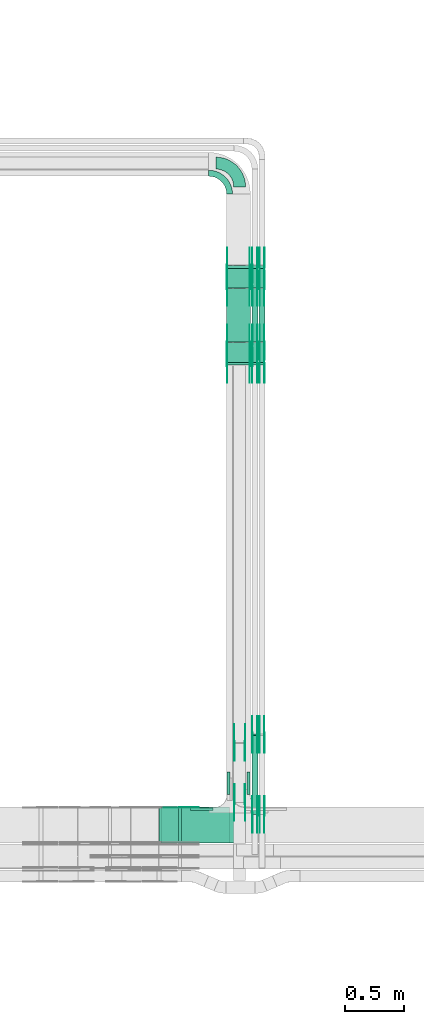
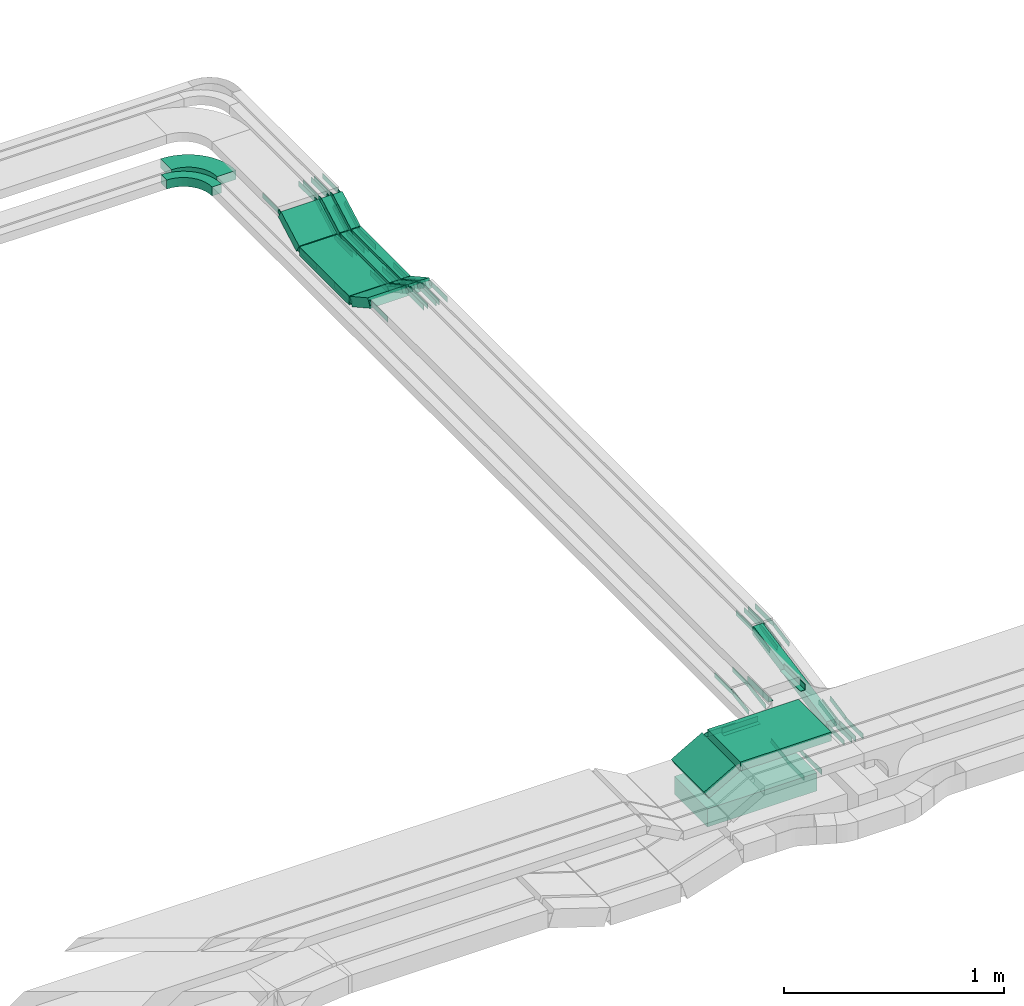
# One storey, part 14 of 28: 79 flow fittings, 13 flow segments.
"""IFC2X3 building model written with IfcOpenShell, lengths in millimetres."""

from ifc_helpers import new_model, entity, si_unit, converted_unit, derived_unit, direction, frame, frame_2d, origin, origin_2d_with_axis, place, context, subcontext, project, spatial, polyline, circle_curve, parameter, trimmed, segment, composite_curve, rectangle, outline, extrude, source, transform, mapped, material, type_object, type_shapes, element, save


model = new_model("IFC2X3")

# Units and contexts
model_context = context("Model", 3, precision=0.01, world=origin(), true_north=direction((6.12303176911189e-17, 1.0)))
body_context = subcontext(model_context, "Body", "Model", "MODEL_VIEW")
ifc_project = project(units=[si_unit("LENGTHUNIT", "METRE", prefix="MILLI"), si_unit("AREAUNIT", "SQUARE_METRE"), si_unit("VOLUMEUNIT", "CUBIC_METRE"), converted_unit("PLANEANGLEUNIT", "DEGREE", entity("IfcRatioMeasure", 0.0174532925199433), si_unit("PLANEANGLEUNIT", "RADIAN"), dimensions=[0, 0, 0, 0, 0, 0, 0]), si_unit("MASSUNIT", "GRAM", prefix="KILO"), derived_unit("MASSDENSITYUNIT", [(si_unit("MASSUNIT", "GRAM", prefix="KILO"), 1), (si_unit("LENGTHUNIT", "METRE"), -3)]), derived_unit("MOMENTOFINERTIAUNIT", [(si_unit("LENGTHUNIT", "METRE"), 4)]), si_unit("TIMEUNIT", "SECOND"), si_unit("FREQUENCYUNIT", "HERTZ"), si_unit("THERMODYNAMICTEMPERATUREUNIT", "DEGREE_CELSIUS"), derived_unit("THERMALTRANSMITTANCEUNIT", [(si_unit("MASSUNIT", "GRAM", prefix="KILO"), 1), (si_unit("THERMODYNAMICTEMPERATUREUNIT", "KELVIN"), -1), (si_unit("TIMEUNIT", "SECOND"), -3)]), derived_unit("VOLUMETRICFLOWRATEUNIT", [(si_unit("LENGTHUNIT", "METRE"), 3), (si_unit("TIMEUNIT", "SECOND"), -1)]), derived_unit("MASSFLOWRATEUNIT", [(si_unit("MASSUNIT", "GRAM", prefix="KILO"), 1), (si_unit("TIMEUNIT", "SECOND"), -1)]), derived_unit("ROTATIONALFREQUENCYUNIT", [(si_unit("TIMEUNIT", "SECOND"), -1)]), si_unit("ELECTRICCURRENTUNIT", "AMPERE"), si_unit("ELECTRICVOLTAGEUNIT", "VOLT"), si_unit("POWERUNIT", "WATT"), si_unit("FORCEUNIT", "NEWTON", prefix="KILO"), si_unit("ILLUMINANCEUNIT", "LUX"), si_unit("LUMINOUSFLUXUNIT", "LUMEN"), si_unit("LUMINOUSINTENSITYUNIT", "CANDELA"), derived_unit("USERDEFINED", [(si_unit("MASSUNIT", "GRAM", prefix="KILO"), -1), (si_unit("LENGTHUNIT", "METRE"), -2), (si_unit("TIMEUNIT", "SECOND"), 3), (si_unit("LUMINOUSFLUXUNIT", "LUMEN"), 1)]), derived_unit("LINEARVELOCITYUNIT", [(si_unit("LENGTHUNIT", "METRE"), 1), (si_unit("TIMEUNIT", "SECOND"), -1)]), si_unit("PRESSUREUNIT", "PASCAL"), derived_unit("USERDEFINED", [(si_unit("LENGTHUNIT", "METRE"), -2), (si_unit("MASSUNIT", "GRAM", prefix="KILO"), 1), (si_unit("TIMEUNIT", "SECOND"), -2)]), derived_unit("LINEARFORCEUNIT", [(si_unit("MASSUNIT", "GRAM", prefix="KILO"), 1), (si_unit("LENGTHUNIT", "METRE"), 1), (si_unit("TIMEUNIT", "SECOND"), -2), (si_unit("LENGTHUNIT", "METRE"), -1)]), derived_unit("PLANARFORCEUNIT", [(si_unit("MASSUNIT", "GRAM", prefix="KILO"), 1), (si_unit("LENGTHUNIT", "METRE"), 1), (si_unit("TIMEUNIT", "SECOND"), -2), (si_unit("LENGTHUNIT", "METRE"), -2)])], contexts=[model_context])

# Site, building, storey
site_placement = place(None, frame((0.0, -0.00077364408347762, 0.0)))
site = spatial("IfcSite", under=ifc_project, at=site_placement, CompositionType="ELEMENT")
building_placement = place(site_placement, origin())
building = spatial("IfcBuilding", under=site, at=building_placement, CompositionType="ELEMENT")
storey_placement = place(building_placement, origin())
storey = spatial("IfcBuildingStorey", under=building, at=storey_placement, CompositionType="ELEMENT", Elevation=0.0)

# Flow segments
cable_carrier_segment_type = type_object("IfcCableCarrierSegmentType", PredefinedType="CABLETRAYSEGMENT")
flow_segment_1_placement = place(storey_placement, frame((34944.2305815424, 8620.00006103523, 2600.0)))
element("IfcFlowSegment", 1, at=flow_segment_1_placement, inside=storey, type_object=cable_carrier_segment_type, context=body_context, shape_type="SweptSolid", body=[
    extrude(rectangle(XDim=574.87795341654, YDim=299.999999999999, at=frame_2d((-2.1600499167107e-12, -5.40012479177676e-13), x_axis=(1.0, 0.0))), frame((287.438976708272, 150.0, 0.0), z_axis=(0.0, 0.0, 1.0), x_axis=(-1.0, 0.0, 0.0)), (0.0, 0.0, 1.0), 100.0),
])
flow_segment_2_placement = place(storey_placement, frame((35117.8214366615, 8620.00006103513, 2850.0)))
element("IfcFlowSegment", 2, at=flow_segment_2_placement, inside=storey, type_object=cable_carrier_segment_type, context=body_context, shape_type="SweptSolid", body=[
    extrude(rectangle(XDim=476.287098297512, YDim=300.000000000001, at=origin_2d_with_axis()), frame((238.143549148756, 150.0, 0.0), z_axis=(0.0, 0.0, 1.0), x_axis=(-1.0, 0.0, 0.0)), (0.0, 0.0, 1.0), 50.0000000000005),
])
flow_segment_3_placement = place(storey_placement, frame((34927.1059649383, 8620.00006103513, 2756.67195783192)))
element("IfcFlowSegment", 3, at=flow_segment_3_placement, inside=storey, type_object=cable_carrier_segment_type, context=body_context, shape_type="SweptSolid", body=[
    extrude(rectangle(XDim=50.0000000000026, YDim=186.565135153123, at=frame_2d((0.0, 0.0), x_axis=(0.0, 1.0))), frame((93.4336609654781, 0.0, 67.8800710275627), z_axis=(0.0, 1.0, 0.0), x_axis=(-0.869016356406515, 0.0, -0.494783358954144)), (0.0, 0.0, 1.0), 299.999999999999),
])
flow_segment_4_placement = place(storey_placement, frame((35495.108534959, 12636.100454036, 2757.25534543462)))
element("IfcFlowSegment", 4, at=flow_segment_4_placement, inside=storey, type_object=cable_carrier_segment_type, context=body_context, shape_type="SweptSolid", body=[
    extrude(rectangle(XDim=49.9999999999987, YDim=189.266714071958, at=frame_2d((0.0, 0.0), x_axis=(0.0, 1.0))), frame((0.0, 94.8884395227133, 67.7446545653522), z_axis=(1.0, 0.0, 0.0), x_axis=(0.0, 0.874619707142013, -0.484809620241615)), (0.0, 0.0, 1.0), 199.999999999998),
])
flow_segment_5_placement = place(storey_placement, frame((35495.108534959, 12829.6911912687, 2750.0)))
element("IfcFlowSegment", 5, at=flow_segment_5_placement, inside=storey, type_object=cable_carrier_segment_type, context=body_context, shape_type="SweptSolid", body=[
    extrude(rectangle(XDim=450.404775530849, YDim=199.999999999998, at=origin_2d_with_axis()), frame((100.0, 225.202387765424, 0.0), z_axis=(0.0, 0.0, 1.0), x_axis=(0.0, 1.0, 0.0)), (0.0, 0.0, 1.0), 49.9999999999995),
])
flow_segment_6_placement = place(storey_placement, frame((35495.108534959, 13283.909824987, 2757.25534543462)))
element("IfcFlowSegment", 6, at=flow_segment_6_placement, inside=storey, type_object=cable_carrier_segment_type, context=body_context, shape_type="SweptSolid", body=[
    extrude(rectangle(XDim=49.9999999999988, YDim=189.266714071933, at=frame_2d((-1.07291953099775e-12, 2.87769807982841e-13), x_axis=(0.0, 1.0))), frame((0.0, 94.8884395226938, 67.7446545653619), z_axis=(1.0, 0.0, 0.0), x_axis=(0.0, -0.874619707141901, -0.484809620241818)), (0.0, 0.0, 1.0), 199.999999999998),
])
flow_segment_7_placement = place(storey_placement, frame((35707.4596505076, 12636.100454036, 2757.25534543462)))
element("IfcFlowSegment", 7, at=flow_segment_7_placement, inside=storey, type_object=cable_carrier_segment_type, context=body_context, shape_type="SweptSolid", body=[
    extrude(rectangle(XDim=49.9999999999985, YDim=49.9999999999973, at=frame_2d((0.0, -2.36255459640233e-13), x_axis=(0.0, 1.0))), frame((25.0, 12.1202405060419, 113.623816452189), z_axis=(0.0, 0.874619707141971, -0.484809620241692), x_axis=(-1.0, 0.0, 0.0)), (0.0, 0.0, 1.0), 189.266714071994),
])
flow_segment_8_placement = place(storey_placement, frame((35707.4596505076, 12829.6911912687, 2750.0)))
element("IfcFlowSegment", 8, at=flow_segment_8_placement, inside=storey, type_object=cable_carrier_segment_type, context=body_context, shape_type="SweptSolid", body=[
    extrude(rectangle(XDim=450.404775530849, YDim=49.9999999999973, at=origin_2d_with_axis()), frame((25.0, 225.202387765424, 0.0), z_axis=(0.0, 0.0, 1.0), x_axis=(0.0, 1.0, 0.0)), (0.0, 0.0, 1.0), 49.9999999999995),
])
flow_segment_9_placement = place(storey_placement, frame((35707.4596505076, 13283.909824987, 2757.25534543462)))
element("IfcFlowSegment", 9, at=flow_segment_9_placement, inside=storey, type_object=cable_carrier_segment_type, context=body_context, shape_type="SweptSolid", body=[
    extrude(rectangle(XDim=49.9999999999974, YDim=49.9999999999973, at=origin_2d_with_axis()), frame((25.0, 12.1202405060463, 21.8654926785462), z_axis=(0.0, 0.874619707141869, 0.484809620241875), x_axis=(0.0, -0.484809620241875, 0.874619707141869)), (0.0, 0.0, 1.0), 189.266714071863),
])
flow_segment_10_placement = place(storey_placement, frame((35767.4596505076, 12636.1004540359, 2757.25534543461)))
element("IfcFlowSegment", 10, at=flow_segment_10_placement, inside=storey, type_object=cable_carrier_segment_type, context=body_context, shape_type="SweptSolid", body=[
    extrude(rectangle(XDim=50.0000000000002, YDim=49.9999999999973, at=frame_2d((0.0, 0.0), x_axis=(0.0, 1.0))), frame((25.0, 12.1202405060354, 113.623816452199), z_axis=(0.0, 0.874619707142124, -0.484809620241415), x_axis=(-1.0, 0.0, 0.0)), (0.0, 0.0, 1.0), 189.266714072121),
])
flow_segment_11_placement = place(storey_placement, frame((35767.4596505076, 12829.6911912687, 2750.0)))
element("IfcFlowSegment", 11, at=flow_segment_11_placement, inside=storey, type_object=cable_carrier_segment_type, context=body_context, shape_type="SweptSolid", body=[
    extrude(rectangle(XDim=450.404775530849, YDim=49.9999999999973, at=origin_2d_with_axis()), frame((25.0, 225.202387765424, 0.0), z_axis=(0.0, 0.0, 1.0), x_axis=(0.0, 1.0, 0.0)), (0.0, 0.0, 1.0), 49.9999999999995),
])
flow_segment_12_placement = place(storey_placement, frame((35767.4596505076, 13283.909824987, 2757.25534543462)))
element("IfcFlowSegment", 12, at=flow_segment_12_placement, inside=storey, type_object=cable_carrier_segment_type, context=body_context, shape_type="SweptSolid", body=[
    extrude(rectangle(XDim=49.9999999999981, YDim=49.9999999999973, at=frame_2d((-9.98312543742941e-13, 0.0), x_axis=(1.0, 0.0))), frame((25.0, 12.1202405060419, 21.8654926785478), z_axis=(0.0, 0.874619707141945, 0.484809620241739), x_axis=(0.0, -0.484809620241739, 0.874619707141945)), (0.0, 0.0, 1.0), 189.266714072015),
])
flow_segment_13_placement = place(storey_placement, frame((35707.4596505076, 8859.24285834248, 2722.15463457333)))
element("IfcFlowSegment", 13, at=flow_segment_13_placement, inside=storey, type_object=cable_carrier_segment_type, context=body_context, shape_type="SweptSolid", body=[
    extrude(rectangle(XDim=50.0000000000005, YDim=49.9999999999973, at=frame_2d((0.0, -1.01252339845814e-13), x_axis=(0.0, 1.0))), frame((25.0, 4.70828965747625, 24.5526375060055), z_axis=(0.0, 0.982105500240211, 0.18833158629907), x_axis=(-1.0, 0.0, 0.0)), (0.0, 0.0, 1.0), 677.451182505788),
])

# Flow fittings
ifc_material_1 = material(Name="G")
cable_carrier_fitting_type_1 = type_object("IfcCableCarrierFittingType", PredefinedType="NOTDEFINED", material=ifc_material_1)
shared_shape_1 = source(origin(), body_context, "Body", "SweptSolid", [
    extrude(outline(composite_curve([segment(trimmed(circle_curve(frame_2d((-44.5901162790698, 0.0), x_axis=(1.0, 0.0)), 12.5), [parameter(90.0000000000007)], [parameter(270.0)], True, "PARAMETER"), True, "CONTINUOUS"), segment(polyline([(-44.5901162790697, -12.5), (-33.0901162790698, -12.5)]), True, "CONTINUOUS"), segment(polyline([(-33.0901162790698, -12.5), (-31.2296511627907, -14.5)]), True, "CONTINUOUS"), segment(polyline([(-31.2296511627907, -14.5), (108.90988372093, -14.5)]), True, "CONTINUOUS"), segment(polyline([(108.90988372093, -14.5), (108.90988372093, 14.5)]), True, "CONTINUOUS"), segment(polyline([(108.90988372093, 14.5), (-31.2296511627907, 14.5)]), True, "CONTINUOUS"), segment(polyline([(-31.2296511627907, 14.5), (-33.0901162790698, 12.5)]), True, "CONTINUOUS"), segment(polyline([(-33.0901162790698, 12.5), (-44.5901162790699, 12.5)]), True, "CONTINUOUS")], self_intersect=False)), frame((44.5901162790698, 0.0, 0.0), z_axis=(0.0, 0.0, -1.0), x_axis=(1.0, 0.0, 0.0)), (0.0, 0.0, -1.0), 2.0),
])
type_shapes(cable_carrier_fitting_type_1, [shared_shape_1])
for number, where, z_axis, x_axis in (
    (14, (35559.6485349488, 9462.24837085622, 2625.0), (-1.0, 0.0, 0.0), (0.0, 1.0, 0.0)),
    (15, (35559.6485349488, 8957.89179254252, 2545.11776562734), (-1.0, 0.0, 0.0), (0.0, -1.0, 0.0)),
    (16, (35109.1442874699, 8915.46006104529, 2875.0), (0.0, 1.0, 0.0), (1.0, 0.0, 0.0)),
    (17, (35499.6485349488, 12640.7865057941, 2875.0), (-1.0, 0.0, 0.0), (0.0, 0.874619707139365, -0.484809620246393)),
    (18, (35499.6485349488, 12821.1912813235, 2775.0), (-1.0, 0.0, 0.0), (0.0, -0.874619707139365, 0.484809620246393)),
    (19, (35690.5685349691, 13469.0006522743, 2875.0), (1.0, 0.0, 0.0), (0.0, -0.874619707139365, -0.484809620246393)),
    (20, (35690.5685349691, 13288.595876745, 2775.0), (1.0, 0.0, 0.0), (0.0, 0.874619707139365, 0.484809620246393)),
    (21, (35711.9996504974, 12821.1912813235, 2775.0), (-1.0, 0.0, 0.0), (0.0, -0.874619707139365, 0.484809620246393)),
    (22, (35752.9196505177, 13288.595876745, 2775.0), (1.0, 0.0, 0.0), (0.0, 0.874619707139365, 0.484809620246393)),
    (23, (35711.9996504974, 13469.0006522742, 2875.0), (-1.0, 0.0, 0.0), (0.0, 1.0, 0.0)),
    (24, (35771.9996504974, 12821.1912813235, 2775.0), (-1.0, 0.0, 0.0), (0.0, -0.874619707139365, 0.484809620246393)),
    (25, (35812.9196505177, 13288.595876745, 2775.0), (1.0, 0.0, 0.0), (0.0, 0.874619707139365, 0.484809620246393)),
    (26, (35771.9996504974, 13469.0006522744, 2875.0), (-1.0, 0.0, 0.0), (0.0, 1.0, 0.0)),
    (27, (35812.9196505177, 12640.7865057939, 2875.0), (1.0, 0.0, 0.0), (0.0, -1.0, 0.0)),
    (28, (35812.9196505177, 8860.26288830369, 2746.0), (1.0, 0.0, 0.0), (0.0, 0.982105500240216, 0.188331586299048)),
    (29, (35812.9196505177, 9532.96794017931, 2875.0), (1.0, 0.0, 0.0), (0.0, -0.982105500240216, -0.188331586299048)),
    (30, (35752.9196505177, 8860.26288830369, 2746.0), (1.0, 0.0, 0.0), (0.0, 0.982105500240216, 0.188331586299048)),
    (31, (35752.9196505177, 12640.7865057941, 2875.0), (1.0, 0.0, 0.0), (0.0, -1.0, 0.0)),
    (32, (35711.9996504974, 9532.96794017937, 2875.0), (-1.0, 0.0, 0.0), (0.0, 1.0, 0.0)),
):
    element("IfcFlowFitting", number, at=place(storey_placement, frame(where, z_axis=z_axis, x_axis=x_axis)), inside=storey, type_object=cable_carrier_fitting_type_1, material=ifc_material_1, context=body_context, shape_type="MappedRepresentation", body=[
        mapped(shared_shape_1, transform((0.0, 0.0, 0.0), scale=1.0)),
    ])
cable_carrier_fitting_type_2 = type_object("IfcCableCarrierFittingType", PredefinedType="NOTDEFINED", material=ifc_material_1)
shared_shape_2 = source(origin(), body_context, "Body", "SweptSolid", [
    extrude(outline(composite_curve([segment(trimmed(circle_curve(frame_2d((-44.5901162790697, 0.0), x_axis=(1.0, 0.0)), 12.5), [parameter(90.0000000000007)], [parameter(270.0)], True, "PARAMETER"), True, "CONTINUOUS"), segment(polyline([(-44.5901162790697, -12.5), (-33.0901162790697, -12.5)]), True, "CONTINUOUS"), segment(polyline([(-33.0901162790697, -12.5), (-31.2296511627907, -14.5)]), True, "CONTINUOUS"), segment(polyline([(-31.2296511627907, -14.5), (108.90988372093, -14.5)]), True, "CONTINUOUS"), segment(polyline([(108.90988372093, -14.5), (108.90988372093, 14.5)]), True, "CONTINUOUS"), segment(polyline([(108.90988372093, 14.5), (-31.2296511627907, 14.5)]), True, "CONTINUOUS"), segment(polyline([(-31.2296511627907, 14.5), (-33.0901162790698, 12.5)]), True, "CONTINUOUS"), segment(polyline([(-33.0901162790698, 12.5), (-44.5901162790699, 12.5)]), True, "CONTINUOUS")], self_intersect=False)), frame((44.5901162790697, 0.0, 0.0)), (0.0, 0.0, 1.0), 2.0),
])
type_shapes(cable_carrier_fitting_type_2, [shared_shape_2])
for number, where, z_axis, x_axis in (
    (33, (35650.5685349691, 9462.24837085621, 2625.0), (1.0, 0.0, 0.0), (0.0, 1.0, 0.0)),
    (34, (35650.5685349691, 8957.89179254252, 2545.11776562734), (1.0, 0.0, 0.0), (0.0, -1.0, 0.0)),
    (35, (35690.5685349691, 12640.7865057941, 2875.0), (1.0, 0.0, 0.0), (0.0, 0.874619707139365, -0.484809620246393)),
    (36, (35690.5685349691, 12821.1912813235, 2775.0), (1.0, 0.0, 0.0), (0.0, -0.874619707139365, 0.484809620246393)),
    (37, (35499.6485349488, 13469.0006522743, 2875.0), (-1.0, 0.0, 0.0), (0.0, -0.874619707139365, -0.484809620246393)),
    (38, (35499.6485349488, 13288.595876745, 2775.0), (-1.0, 0.0, 0.0), (0.0, 0.874619707139365, 0.484809620246393)),
    (39, (35752.9196505177, 12821.1912813235, 2775.0), (1.0, 0.0, 0.0), (0.0, -0.874619707139365, 0.484809620246393)),
    (40, (35711.9996504974, 13288.595876745, 2775.0), (-1.0, 0.0, 0.0), (0.0, 0.874619707139365, 0.484809620246393)),
    (41, (35752.9196505177, 13469.0006522742, 2875.0), (1.0, 0.0, 0.0), (0.0, 1.0, 0.0)),
    (42, (35812.9196505177, 12821.1912813235, 2775.0), (1.0, 0.0, 0.0), (0.0, -0.874619707139365, 0.484809620246393)),
    (43, (35771.9996504974, 13288.595876745, 2775.0), (-1.0, 0.0, 0.0), (0.0, 0.874619707139365, 0.484809620246393)),
    (44, (35812.9196505177, 13469.0006522744, 2875.0), (1.0, 0.0, 0.0), (0.0, 1.0, 0.0)),
    (45, (35771.9996504974, 12640.7865057939, 2875.0), (-1.0, 0.0, 0.0), (0.0, -1.0, 0.0)),
    (46, (35771.9996504974, 8860.26288830368, 2746.0), (-1.0, 0.0, 0.0), (0.0, 0.982105500240216, 0.188331586299048)),
    (47, (35771.9996504974, 9532.96794017931, 2875.0), (-1.0, 0.0, 0.0), (0.0, -0.982105500240216, -0.188331586299048)),
    (48, (35711.9996504974, 8860.26288830368, 2746.0), (-1.0, 0.0, 0.0), (0.0, 0.982105500240216, 0.188331586299048)),
    (49, (35711.9996504974, 12640.7865057941, 2875.0), (-1.0, 0.0, 0.0), (0.0, -1.0, 0.0)),
    (50, (35752.9196505177, 9532.96794017937, 2875.0), (1.0, 0.0, 0.0), (0.0, 1.0, 0.0)),
):
    element("IfcFlowFitting", number, at=place(storey_placement, frame(where, z_axis=z_axis, x_axis=x_axis)), inside=storey, type_object=cable_carrier_fitting_type_2, material=ifc_material_1, context=body_context, shape_type="MappedRepresentation", body=[
        mapped(shared_shape_2, transform((0.0, 0.0, 0.0), scale=1.0)),
    ])
cable_carrier_fitting_type_3 = type_object("IfcCableCarrierFittingType", PredefinedType="NOTDEFINED", material=ifc_material_1)
shared_shape_3 = source(origin(), body_context, "Body", "SweptSolid", [
    extrude(outline(composite_curve([segment(trimmed(circle_curve(frame_2d((-44.5901162790698, 0.0), x_axis=(1.0, 0.0)), 12.5), [parameter(90.0000000000007)], [parameter(270.0)], True, "PARAMETER"), True, "CONTINUOUS"), segment(polyline([(-44.5901162790697, -12.5), (-33.0901162790698, -12.5)]), True, "CONTINUOUS"), segment(polyline([(-33.0901162790698, -12.5), (-31.2296511627907, -14.5)]), True, "CONTINUOUS"), segment(polyline([(-31.2296511627907, -14.5), (108.90988372093, -14.5)]), True, "CONTINUOUS"), segment(polyline([(108.90988372093, -14.5), (108.90988372093, 14.5)]), True, "CONTINUOUS"), segment(polyline([(108.90988372093, 14.5), (-31.2296511627907, 14.5)]), True, "CONTINUOUS"), segment(polyline([(-31.2296511627907, 14.5), (-33.0901162790698, 12.5)]), True, "CONTINUOUS"), segment(polyline([(-33.0901162790698, 12.5), (-44.5901162790699, 12.5)]), True, "CONTINUOUS")], self_intersect=False)), frame((44.5901162790698, 0.0, 0.0), z_axis=(0.0, 0.0, -1.0), x_axis=(1.0, 0.0, 0.0)), (0.0, 0.0, -1.0), 2.0),
])
type_shapes(cable_carrier_fitting_type_3, [shared_shape_3])
for number, where, z_axis, x_axis in (
    (51, (35648.5685349691, 9462.24837085623, 2625.0), (1.0, 0.0, 0.0), (0.0, -0.987688340595135, -0.15643446504025)),
    (52, (35648.5685349691, 8957.8917925425, 2545.11776562734), (1.0, 0.0, 0.0), (0.0, 0.987688340597445, 0.15643446502566)),
    (53, (35688.5685349691, 12640.7865057941, 2875.0), (1.0, 0.0, 0.0), (0.0, -1.0, 0.0)),
    (54, (35688.5685349691, 12821.1912813235, 2775.0), (1.0, 0.0, 0.0), (0.0, 1.0, 0.0)),
    (55, (35501.6485349488, 13469.0006522743, 2875.0), (-1.0, 0.0, 0.0), (0.0, 1.0, 0.0)),
    (56, (35501.6485349488, 13288.595876745, 2775.0), (-1.0, 0.0, 0.0), (0.0, -1.0, 0.0)),
    (57, (35750.9196505177, 12821.1912813235, 2775.0), (1.0, 0.0, 0.0), (0.0, 1.0, 0.0)),
    (58, (35713.9996504974, 13288.595876745, 2775.0), (-1.0, 0.0, 0.0), (0.0, -1.0, 0.0)),
    (59, (35750.9196505177, 13469.0006522742, 2875.0), (1.0, 0.0, 0.0), (0.0, -0.874619707141878, -0.484809620241859)),
    (60, (35810.9196505177, 12821.1912813235, 2775.0), (1.0, 0.0, 0.0), (0.0, 1.0, 0.0)),
    (61, (35773.9996504974, 13288.595876745, 2775.0), (-1.0, 0.0, 0.0), (0.0, -1.0, 0.0)),
    (62, (35810.9196505177, 13469.0006522744, 2875.0), (1.0, 0.0, 0.0), (0.0, -0.874619707141963, -0.484809620241705)),
    (63, (35773.9996504974, 12640.7865057939, 2875.0), (-1.0, 0.0, 0.0), (0.0, 0.874619707142149, -0.484809620241371)),
    (64, (35773.9996504974, 8860.2628883037, 2746.0), (-1.0, 0.0, 0.0), (0.0, -1.0, 0.0)),
    (65, (35773.9996504974, 9532.96794017929, 2875.0), (-1.0, 0.0, 0.0), (0.0, 1.0, 0.0)),
    (66, (35713.9996504974, 8860.2628883037, 2746.0), (-1.0, 0.0, 0.0), (0.0, -1.0, 0.0)),
    (67, (35713.9996504974, 12640.7865057941, 2875.0), (-1.0, 0.0, 0.0), (0.0, 0.874619707141962, -0.484809620241708)),
    (68, (35750.9196505177, 9532.96794017939, 2875.0), (1.0, 0.0, 0.0), (0.0, -0.982105500240217, -0.188331586299042)),
):
    element("IfcFlowFitting", number, at=place(storey_placement, frame(where, z_axis=z_axis, x_axis=x_axis)), inside=storey, type_object=cable_carrier_fitting_type_3, material=ifc_material_1, context=body_context, shape_type="MappedRepresentation", body=[
        mapped(shared_shape_3, transform((0.0, 0.0, 0.0), scale=1.0)),
    ])
cable_carrier_fitting_type_4 = type_object("IfcCableCarrierFittingType", PredefinedType="NOTDEFINED", material=ifc_material_1)
shared_shape_4 = source(origin(), body_context, "Body", "SweptSolid", [
    extrude(outline(composite_curve([segment(trimmed(circle_curve(frame_2d((-44.5901162790697, 0.0), x_axis=(1.0, 0.0)), 12.5), [parameter(90.0000000000007)], [parameter(270.0)], True, "PARAMETER"), True, "CONTINUOUS"), segment(polyline([(-44.5901162790697, -12.5), (-33.0901162790697, -12.5)]), True, "CONTINUOUS"), segment(polyline([(-33.0901162790697, -12.5), (-31.2296511627907, -14.5)]), True, "CONTINUOUS"), segment(polyline([(-31.2296511627907, -14.5), (108.90988372093, -14.5)]), True, "CONTINUOUS"), segment(polyline([(108.90988372093, -14.5), (108.90988372093, 14.5)]), True, "CONTINUOUS"), segment(polyline([(108.90988372093, 14.5), (-31.2296511627907, 14.5)]), True, "CONTINUOUS"), segment(polyline([(-31.2296511627907, 14.5), (-33.0901162790698, 12.5)]), True, "CONTINUOUS"), segment(polyline([(-33.0901162790698, 12.5), (-44.5901162790699, 12.5)]), True, "CONTINUOUS")], self_intersect=False)), frame((44.5901162790697, 0.0, 0.0)), (0.0, 0.0, 1.0), 2.0),
])
type_shapes(cable_carrier_fitting_type_4, [shared_shape_4])
for number, where, z_axis, x_axis in (
    (69, (35561.6485349488, 9462.24837085624, 2625.0), (-1.0, 0.0, 0.0), (0.0, -0.987688340595135, -0.15643446504025)),
    (70, (35561.6485349488, 8957.8917925425, 2545.11776562735), (-1.0, 0.0, 0.0), (0.0, 0.987688340597445, 0.15643446502566)),
    (71, (35109.1442874699, 8913.46006104529, 2875.0), (0.0, 1.0, 0.0), (-0.869016356406542, 0.0, -0.494783358954097)),
    (72, (35501.6485349488, 12640.7865057941, 2875.0), (-1.0, 0.0, 0.0), (0.0, -1.0, 0.0)),
    (73, (35501.6485349488, 12821.1912813235, 2775.0), (-1.0, 0.0, 0.0), (0.0, 1.0, 0.0)),
    (74, (35688.5685349691, 13469.0006522743, 2875.0), (1.0, 0.0, 0.0), (0.0, 1.0, 0.0)),
    (75, (35688.5685349691, 13288.595876745, 2775.0), (1.0, 0.0, 0.0), (0.0, -1.0, 0.0)),
    (76, (35713.9996504974, 12821.1912813235, 2775.0), (-1.0, 0.0, 0.0), (0.0, 1.0, 0.0)),
    (77, (35750.9196505177, 13288.595876745, 2775.0), (1.0, 0.0, 0.0), (0.0, -1.0, 0.0)),
    (78, (35713.9996504974, 13469.0006522742, 2875.0), (-1.0, 0.0, 0.0), (0.0, -0.874619707141878, -0.484809620241859)),
    (79, (35773.9996504974, 12821.1912813235, 2775.0), (-1.0, 0.0, 0.0), (0.0, 1.0, 0.0)),
    (80, (35810.9196505177, 13288.595876745, 2775.0), (1.0, 0.0, 0.0), (0.0, -1.0, 0.0)),
    (81, (35773.9996504974, 13469.0006522744, 2875.0), (-1.0, 0.0, 0.0), (0.0, -0.874619707141963, -0.484809620241705)),
    (82, (35810.9196505177, 12640.7865057939, 2875.0), (1.0, 0.0, 0.0), (0.0, 0.874619707142149, -0.484809620241371)),
    (83, (35810.9196505177, 8860.2628883037, 2746.0), (1.0, 0.0, 0.0), (0.0, -1.0, 0.0)),
    (84, (35810.9196505177, 9532.96794017929, 2875.0), (1.0, 0.0, 0.0), (0.0, 1.0, 0.0)),
    (85, (35750.9196505177, 8860.2628883037, 2746.0), (1.0, 0.0, 0.0), (0.0, -1.0, 0.0)),
    (86, (35750.9196505177, 12640.7865057941, 2875.0), (1.0, 0.0, 0.0), (0.0, 0.874619707141962, -0.484809620241708)),
    (87, (35713.9996504974, 9532.96794017939, 2875.0), (-1.0, 0.0, 0.0), (0.0, -0.982105500240217, -0.188331586299042)),
):
    element("IfcFlowFitting", number, at=place(storey_placement, frame(where, z_axis=z_axis, x_axis=x_axis)), inside=storey, type_object=cable_carrier_fitting_type_4, material=ifc_material_1, context=body_context, shape_type="MappedRepresentation", body=[
        mapped(shared_shape_4, transform((0.0, 0.0, 0.0), scale=1.0)),
    ])
ifc_material_2 = material()
cable_carrier_fitting_type_5 = type_object("IfcCableCarrierFittingType", PredefinedType="NOTDEFINED", material=ifc_material_2)
shared_shape_5 = source(origin(), body_context, "Body", "SweptSolid", [
    extrude(outline(polyline([(-9.16666666666668, -11.5000000000001), (15.8333333333333, -11.5000000000001), (15.8333333333333, -9.0), (-6.66666666666664, -9.0), (-6.66666666666664, 20.5), (-9.16666666666668, 20.5), (-9.16666666666668, -11.5000000000001)])), frame((-95.0, 9.16666666666668, -11.0), z_axis=(1.0, 0.0, 0.0), x_axis=(0.0, 1.0, 0.0)), (0.0, 0.0, 1.0), 190.0),
])
type_shapes(cable_carrier_fitting_type_5, [shared_shape_5])
for number, where, z_axis, x_axis in (
    (88, (35497.608534959, 9120.00006103513, 2875.0), (0.0, 0.0, 1.0), (0.0, -1.0, 0.0)),
    (89, (35692.608534959, 9120.00006103513, 2875.0), (0.0, 0.0, 1.0), (0.0, 1.0, 0.0)),
):
    element("IfcFlowFitting", number, at=place(storey_placement, frame(where, z_axis=z_axis, x_axis=x_axis)), inside=storey, type_object=cable_carrier_fitting_type_5, material=ifc_material_2, context=body_context, shape_type="MappedRepresentation", body=[
        mapped(shared_shape_5, transform((0.0, 0.0, 0.0), scale=1.0)),
    ])
cable_carrier_fitting_type_6 = type_object("IfcCableCarrierFittingType", PredefinedType="NOTDEFINED", material=ifc_material_2)
shared_shape_6 = source(origin(), body_context, "Body", "SweptSolid", [
    extrude(outline(polyline([(-11.5000000000001, -9.16666666666668), (20.5, -9.16666666666668), (20.5, -6.66666666666664), (-9.0, -6.66666666666664), (-9.0, 15.8333333333333), (-11.5000000000001, 15.8333333333333), (-11.5000000000001, -9.16666666666668)])), frame((-95.0, -9.16666666666668, -11.0), z_axis=(1.0, 0.0, 0.0), x_axis=(0.0, 0.0, 1.0)), (0.0, 0.0, 1.0), 190.0),
])
type_shapes(cable_carrier_fitting_type_6, [shared_shape_6])
flow_fitting_1_placement = place(storey_placement, frame((35285.108534959, 8917.50006103513, 2875.0)))
element("IfcFlowFitting", 90, at=flow_fitting_1_placement, inside=storey, type_object=cable_carrier_fitting_type_6, material=ifc_material_2, context=body_context, shape_type="MappedRepresentation", body=[
    mapped(shared_shape_6, transform((0.0, 0.0, 0.0), scale=1.0)),
])
ifc_material_3 = material()
cable_carrier_fitting_type_7 = type_object("IfcCableCarrierFittingType", Name="470_DKC_S5_Variable Angle Elbow 0-45:-", PredefinedType="NOTDEFINED", material=ifc_material_3)
shared_shape_7 = source(origin(), body_context, "Body", "SweptSolid", [
    extrude(outline(composite_curve([segment(polyline([(-100.750000000001, -150.25), (-99.7499999999994, -150.25)]), True, "CONTINUOUS"), segment(trimmed(circle_curve(frame_2d((-99.7499999999997, 99.7499999999995), x_axis=(0.0, -1.0)), 250.0), [parameter(0.0)], [parameter(90.0000000000001)], True, "PARAMETER"), True, "CONTINUOUS"), segment(polyline([(150.25, 99.75), (150.25, 100.749999999999)]), True, "CONTINUOUS"), segment(polyline([(150.25, 100.749999999999), (50.25, 100.75)]), True, "CONTINUOUS"), segment(polyline([(50.25, 100.75), (50.25, 99.7499999999998)]), True, "CONTINUOUS"), segment(trimmed(circle_curve(frame_2d((-99.7499999999997, 99.7499999999995), x_axis=(0.0, -1.0)), 150.0), [parameter(0.0)], [parameter(90.0000000000001)], True, "PARAMETER"), False, "CONTINUOUS"), segment(polyline([(-99.7499999999994, -50.2500000000003), (-100.750000000001, -50.2500000000003)]), True, "CONTINUOUS"), segment(polyline([(-100.750000000001, -50.2500000000003), (-100.750000000001, -150.25)]), True, "CONTINUOUS")], self_intersect=False)), frame((-100.249999999991, 100.249999999992, -25.0)), (0.0, 0.0, 1.0), 49.9999999999997),
])
type_shapes(cable_carrier_fitting_type_7, [shared_shape_7])
flow_fitting_2_placement = place(storey_placement, frame((35605.1085349589, 14335.0, 2625.0), z_axis=(0.0, 0.0, 1.0), x_axis=(0.0, 1.0, 0.0)))
element("IfcFlowFitting", 91, at=flow_fitting_2_placement, inside=storey, type_object=cable_carrier_fitting_type_7, material=ifc_material_3, Name="470_DKC_S5_Variable Angle Elbow 0-45:-", ObjectType="470_DKC_S5_Variable Angle Elbow 0-45:-", context=body_context, shape_type="MappedRepresentation", body=[
    mapped(shared_shape_7, transform((0.0, 0.0, 0.0), scale=1.0)),
])
cable_carrier_fitting_type_8 = type_object("IfcCableCarrierFittingType", Name="470_DKC_S5_Variable Angle Elbow 0-45:-", PredefinedType="NOTDEFINED", material=ifc_material_3)
shared_shape_8 = source(origin(), body_context, "Body", "SweptSolid", [
    extrude(outline(composite_curve([segment(polyline([(-88.2500000000001, -112.75), (-87.2499999999989, -112.75)]), True, "CONTINUOUS"), segment(trimmed(circle_curve(frame_2d((-87.2500000000001, 87.2499999999992), x_axis=(0.0, -1.0)), 200.0), [parameter(0.0)], [parameter(90.0000000000001)], True, "PARAMETER"), True, "CONTINUOUS"), segment(polyline([(112.75, 87.2500000000004), (112.75, 88.2500000000002)]), True, "CONTINUOUS"), segment(polyline([(112.75, 88.2500000000002), (62.7499999999997, 88.2500000000005)]), True, "CONTINUOUS"), segment(polyline([(62.7499999999997, 88.2500000000005), (62.7499999999997, 87.2500000000001)]), True, "CONTINUOUS"), segment(trimmed(circle_curve(frame_2d((-87.2500000000001, 87.2499999999992), x_axis=(0.0, -1.0)), 150.0), [parameter(0.0)], [parameter(90.0000000000001)], True, "PARAMETER"), False, "CONTINUOUS"), segment(polyline([(-87.2499999999991, -62.7500000000006), (-88.2500000000003, -62.7500000000006)]), True, "CONTINUOUS"), segment(polyline([(-88.2500000000003, -62.7500000000006), (-88.2500000000001, -112.75)]), True, "CONTINUOUS")], self_intersect=False)), frame((-87.7499999999907, 87.749999999992, -25.0)), (0.0, 0.0, 1.0), 50.0000000000007),
])
type_shapes(cable_carrier_fitting_type_8, [shared_shape_8])
flow_fitting_3_placement = place(storey_placement, frame((35520.108534959, 14250.0, 2625.0), z_axis=(0.0, 0.0, 1.0), x_axis=(0.0, 1.0, 0.0)))
element("IfcFlowFitting", 92, at=flow_fitting_3_placement, inside=storey, type_object=cable_carrier_fitting_type_8, material=ifc_material_3, Name="470_DKC_S5_Variable Angle Elbow 0-45:-", ObjectType="470_DKC_S5_Variable Angle Elbow 0-45:-", context=body_context, shape_type="MappedRepresentation", body=[
    mapped(shared_shape_8, transform((0.0, 0.0, 0.0), scale=1.0)),
])

save(model, "model.ifc")
